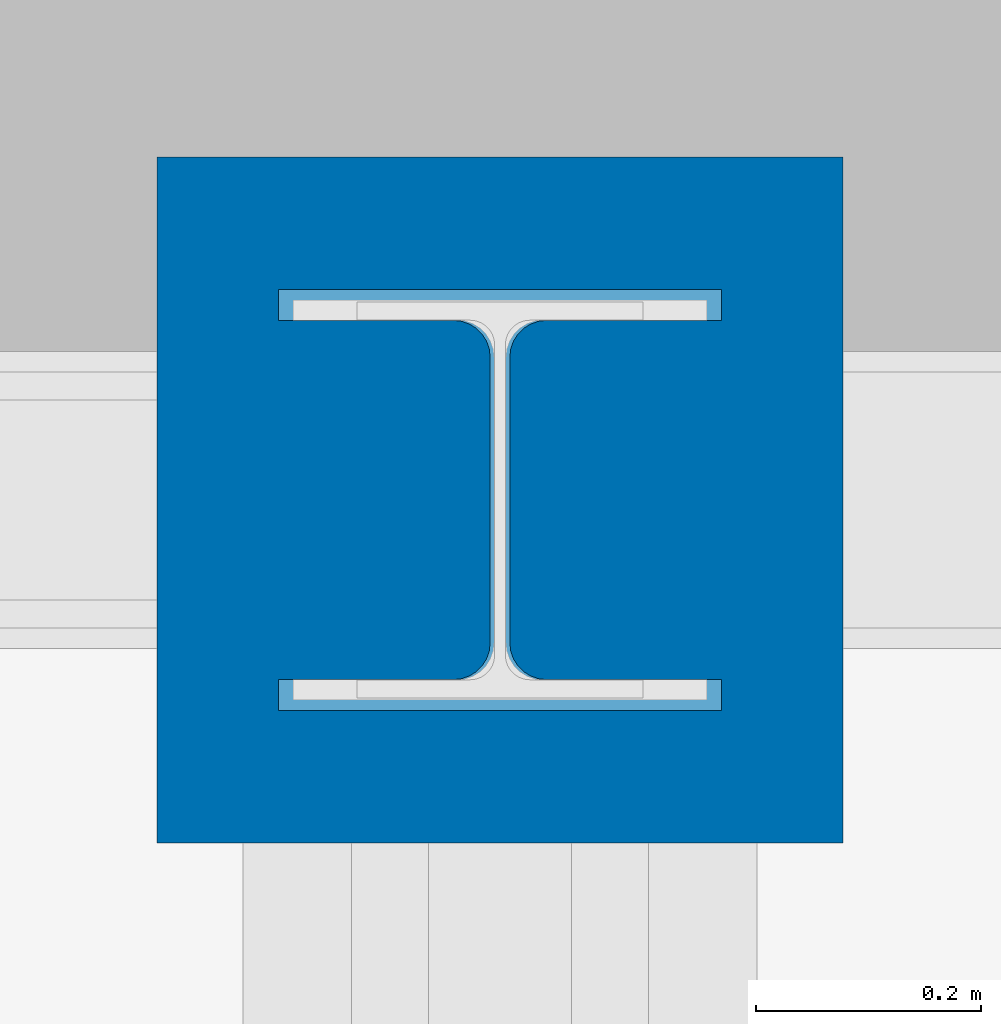
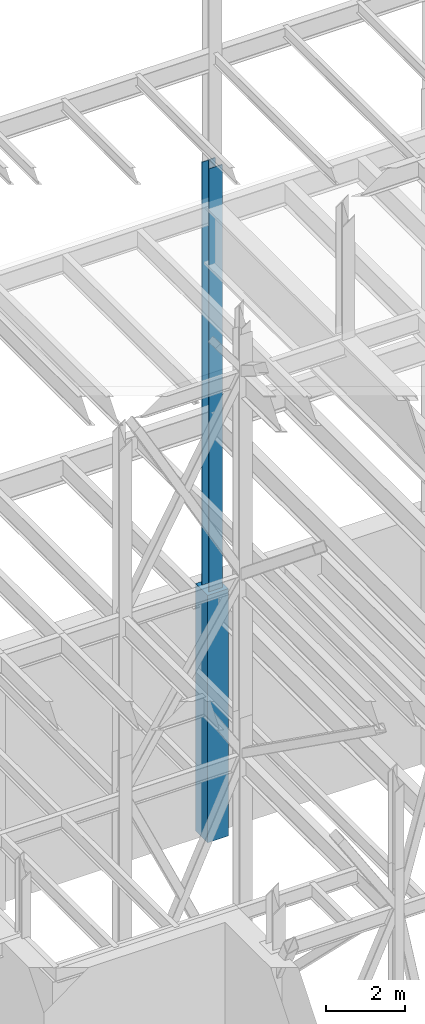
# One storey, part 57 of 150: 2 columns.
"""IFC2X3 building model written with IfcOpenShell, lengths in millimetres."""

import ifcopenshell
import ifcopenshell.guid

model = None  # the IFC model being written
_history = None  # IfcOwnerHistory: only IFC2X3 demands one
_inside = {}  # id of a spatial element -> (the spatial element, [elements in it])
_under = {}  # id of a project, library or spatial element -> (it, [spatial elements below it])
_declared = {}  # id of a project -> (the project, [libraries it declares])
_typed = {}  # id of a type object -> (the type object, [elements of that type])
_made_of = {}  # id of a material, layer set ... -> (it, [elements and type objects made of it])


def new_model(schema):
    """Start an empty IFC model of exactly this schema.

    Asked for "IFC4X3", IfcOpenShell would pick the latest addendum, in which some entities
    have other attributes; the version numbers below select the first issue.
    IFC2X3 requires an IfcOwnerHistory on every rooted entity: one is made here for all.
    """
    global model, _history
    if schema == "IFC4X3":
        model = ifcopenshell.file(schema_version=(4, 3, 0, 0))
    else:
        model = ifcopenshell.file(schema=schema)
    _inside.clear()
    _under.clear()
    _declared.clear()
    _typed.clear()
    _made_of.clear()
    _history = None
    if model.schema == "IFC2X3":
        org = make("IfcOrganization", Name="unknown")
        user = make(
            "IfcPersonAndOrganization",
            ThePerson=make("IfcPerson", FamilyName="unknown"),
            TheOrganization=org,
        )
        app = make(
            "IfcApplication",
            ApplicationDeveloper=org,
            Version="unknown",
            ApplicationFullName="unknown",
            ApplicationIdentifier="unknown",
        )
        _history = make(
            "IfcOwnerHistory",
            OwningUser=user,
            OwningApplication=app,
            ChangeAction="ADDED",
            CreationDate=0,
        )
    return model


def make(cls, **values):
    """One entity of the class cls with the attributes given. An attribute that is None is left unset."""
    return model.create_entity(
        cls, **{name: value for name, value in values.items() if value is not None}
    )


def rooted(cls, **values):
    """An entity with a GlobalId (a new one), such as an element, a storey or a relation."""
    return make(cls, GlobalId=ifcopenshell.guid.new(), OwnerHistory=_history, **values)


def si_unit(unit_type, name, prefix=None):
    """IfcSIUnit, for example si_unit("LENGTHUNIT", "METRE", prefix="MILLI")."""
    return make("IfcSIUnit", UnitType=unit_type, Prefix=prefix, Name=name)


def assignment(units):
    """IfcUnitAssignment: the units of a project."""
    return None if units is None else make("IfcUnitAssignment", Units=units)


def point(xyz):
    """IfcCartesianPoint."""
    return None if xyz is None else make("IfcCartesianPoint", Coordinates=xyz)


def direction(xyz):
    """IfcDirection."""
    return None if xyz is None else make("IfcDirection", DirectionRatios=xyz)


def frame(location, z_axis=None, x_axis=None):
    """IfcAxis2Placement3D, a coordinate frame: its origin and axes. An axis left out is left unset."""
    return make(
        "IfcAxis2Placement3D",
        Location=point(location),
        Axis=direction(z_axis),
        RefDirection=direction(x_axis),
    )


def frame_2d(location, x_axis=None):
    """IfcAxis2Placement2D, a coordinate frame in the plane: its origin and x axis."""
    return make(
        "IfcAxis2Placement2D", Location=point(location), RefDirection=direction(x_axis)
    )


def origin_with_axes():
    """The frame at (0, 0, 0) with the z axis (0, 0, 1) and the x axis (1, 0, 0) written out."""
    return frame((0.0, 0.0, 0.0), z_axis=(0.0, 0.0, 1.0), x_axis=(1.0, 0.0, 0.0))


def origin_2d_with_axis():
    """The frame at (0, 0) in the plane with the x axis (1, 0) written out."""
    return frame_2d((0.0, 0.0), x_axis=(1.0, 0.0))


def place(relative_to, where):
    """IfcLocalPlacement: puts the frame where relative to a parent placement (None: the world)."""
    return make(
        "IfcLocalPlacement", PlacementRelTo=relative_to, RelativePlacement=where
    )


def context(
    kind, dimensions, precision=None, world=None, true_north=None, identifier=None
):
    """IfcGeometricRepresentationContext, for example the 3D "Model" context."""
    return make(
        "IfcGeometricRepresentationContext",
        ContextIdentifier=identifier,
        ContextType=kind,
        CoordinateSpaceDimension=dimensions,
        Precision=precision,
        WorldCoordinateSystem=world,
        TrueNorth=true_north,
    )


def subcontext(parent, identifier, kind, view, scale=None):
    """IfcGeometricRepresentationSubContext, for example "Body" below "Model"."""
    return make(
        "IfcGeometricRepresentationSubContext",
        ContextIdentifier=identifier,
        ContextType=kind,
        ParentContext=parent,
        TargetScale=scale,
        TargetView=view,
    )


def project(units=None, contexts=None):
    """IfcProject with its units and contexts."""
    return rooted(
        "IfcProject",
        Name="project",
        RepresentationContexts=contexts,
        UnitsInContext=assignment(units),
    )


def spatial(cls, under=None, at=None, **own):
    """A site, building, storey or space (cls), placed at a placement, below another one or the project."""
    s = rooted(cls, ObjectPlacement=at, **own)
    if under is not None:
        _under.setdefault(under.id(), (under, []))[1].append(s)
    return s


def profile(cls, at=None, kind="AREA", **sizes):
    """A parametric profile (cls). Its sizes go by their IFC names, for example OverallWidth=200.0."""
    return make(cls, ProfileType=kind, Position=at, **sizes)


def rectangle(**sizes):
    """IfcRectangleProfileDef."""
    return profile("IfcRectangleProfileDef", **sizes)


def i_section(**sizes):
    """IfcIShapeProfileDef."""
    return profile("IfcIShapeProfileDef", **sizes)


def extrude(swept, where, along, depth):
    """IfcExtrudedAreaSolid: the profile swept, set in the frame where, extruded along a direction by depth."""
    return make(
        "IfcExtrudedAreaSolid",
        SweptArea=swept,
        Position=where,
        ExtrudedDirection=direction(along),
        Depth=depth,
    )


def shape(context_of_items, identifier, shape_type, items):
    """IfcShapeRepresentation: the items that make up one representation, for example the "Body"."""
    return make(
        "IfcShapeRepresentation",
        ContextOfItems=context_of_items,
        RepresentationIdentifier=identifier,
        RepresentationType=shape_type,
        Items=items,
    )


def material(Name=None, Category=None):
    """IfcMaterial."""
    return make("IfcMaterial", Name=Name, Category=Category)


def made_of(thing, what):
    """Note that an element or type object is made of a material, layer set ...; save() writes the relation."""
    if what is not None:
        _made_of.setdefault(what.id(), (what, []))[1].append(thing)
    return thing


def type_object(cls, material=None, **own):
    """A type object (cls), such as IfcWallType, which elements share."""
    return made_of(rooted(cls, **own), material)


def element(
    cls,
    number,
    at=None,
    inside=None,
    cuts=None,
    type_object=None,
    material=None,
    context=None,
    identifier="Body",
    shape_type=None,
    held_by="IfcProductDefinitionShape",
    body=None,
    shapes=None,
    **own,
):
    """One element of the class cls, such as IfcWall. Its Tag is "e" and its number.

    at: its placement. inside: the storey or other place that contains it. cuts: it is an
    opening in that element (IfcRelVoidsElement). A single representation is given by context,
    identifier, shape_type and body (its items); several are given by shapes. held_by: the class
    of the entity that holds the representations. save() writes the other relations.
    """
    e = rooted(cls, Tag="e%d" % number, ObjectPlacement=at, **own)
    if body is not None:
        shapes = [shape(context, identifier, shape_type, body)]
    if shapes is not None:
        e.Representation = make(held_by, Representations=shapes)
    if inside is not None:
        _inside.setdefault(inside.id(), (inside, []))[1].append(e)
    if cuts is not None:
        rooted(
            "IfcRelVoidsElement", RelatingBuildingElement=cuts, RelatedOpeningElement=e
        )
    if type_object is not None:
        _typed.setdefault(type_object.id(), (type_object, []))[1].append(e)
    return made_of(e, material)


def aggregate(whole, parts):
    """IfcRelAggregates: a whole, such as a stair, and the parts it consists of."""
    return rooted("IfcRelAggregates", RelatingObject=whole, RelatedObjects=parts)


def save(model, path):
    """Write the relations noted so far, then the file.

    IfcRelAggregates (storeys below a building ...), IfcRelContainedInSpatialStructure (elements
    in a storey), IfcRelDefinesByType, IfcRelAssociatesMaterial and IfcRelDeclares: one each for
    every whole, place, type object, material and project.
    """
    for whole, parts in _under.values():
        aggregate(whole, parts)
    for where, things in _inside.values():
        rooted(
            "IfcRelContainedInSpatialStructure",
            RelatedElements=things,
            RelatingStructure=where,
        )
    for kind, things in _typed.values():
        rooted("IfcRelDefinesByType", RelatedObjects=things, RelatingType=kind)
    for what, things in _made_of.values():
        rooted("IfcRelAssociatesMaterial", RelatedObjects=things, RelatingMaterial=what)
    for by, libraries in _declared.values():
        rooted("IfcRelDeclares", RelatingContext=by, RelatedDefinitions=libraries)
    model.write(path)


model = new_model("IFC2X3")

# Units and contexts
model_context = context("Model", 3, precision=1e-05, world=origin_with_axes())
body_context = subcontext(model_context, "Body", "Model", "MODEL_VIEW")
ifc_project = project(units=[si_unit("LENGTHUNIT", "METRE", prefix="MILLI"), si_unit("AREAUNIT", "SQUARE_METRE"), si_unit("VOLUMEUNIT", "CUBIC_METRE"), si_unit("MASSUNIT", "GRAM", prefix="KILO"), si_unit("TIMEUNIT", "SECOND"), si_unit("PLANEANGLEUNIT", "RADIAN"), si_unit("SOLIDANGLEUNIT", "STERADIAN"), si_unit("THERMODYNAMICTEMPERATUREUNIT", "DEGREE_CELSIUS"), si_unit("LUMINOUSINTENSITYUNIT", "LUMEN")], contexts=[model_context])

# Site, building, storey
site_placement = place(None, origin_with_axes())
site = spatial("IfcSite", under=ifc_project, at=site_placement, CompositionType="ELEMENT")
building_placement = place(site_placement, origin_with_axes())
building = spatial("IfcBuilding", under=site, at=building_placement, Name="Undefined", CompositionType="ELEMENT")
storey_placement = place(building_placement, origin_with_axes())
storey = spatial("IfcBuildingStorey", under=building, at=storey_placement, Name="Undefined", CompositionType="ELEMENT", Elevation=0.0)

# Columns
ifc_material_1 = material(Name="STEEL/A992")
column_type_1 = type_object("IfcColumnType", Name="W14X145", PredefinedType="NOTDEFINED")
column_1_placement = place(storey_placement, frame((11785.6, 38862.0, 22707.6), z_axis=(0.0, 0.0, 1.0), x_axis=(1.0, 0.0, 0.0)))
element("IfcColumn", 1, at=column_1_placement, inside=storey, type_object=column_type_1, material=ifc_material_1, Name="COLUMN", ObjectType="W14X145", context=body_context, shape_type="SweptSolid", body=[
    extrude(i_section(OverallWidth=393.7, OverallDepth=374.65, WebThickness=17.4625, FlangeThickness=27.686, FilletRadius=32.6389, at=origin_2d_with_axis()), frame((0.0, 0.0, 14097.0012877801), z_axis=(0.0, 0.0, -1.0), x_axis=(-1.0, 0.0, 0.0)), (0.0, 0.0, 1.0), 14097.0012877801),
])
ifc_material_2 = material(Name="CONCRETE/5000")
column_type_2 = type_object("IfcColumnType", PredefinedType="NOTDEFINED")
column_2_placement = place(storey_placement, frame((11785.6, 38862.0, 16154.4), z_axis=(0.0, 0.0, 1.0), x_axis=(1.0, 0.0, 0.0)))
element("IfcColumn", 2, at=column_2_placement, inside=storey, type_object=column_type_2, material=ifc_material_2, Name="COLUMN", context=body_context, shape_type="SweptSolid", body=[
    extrude(rectangle(XDim=609.6, YDim=609.6, at=origin_2d_with_axis()), frame((0.0, 0.0, 7620.0), z_axis=(0.0, 0.0, -1.0), x_axis=(0.0, -1.0, 0.0)), (0.0, 0.0, 1.0), 7620.0),
])

save(model, "model.ifc")
